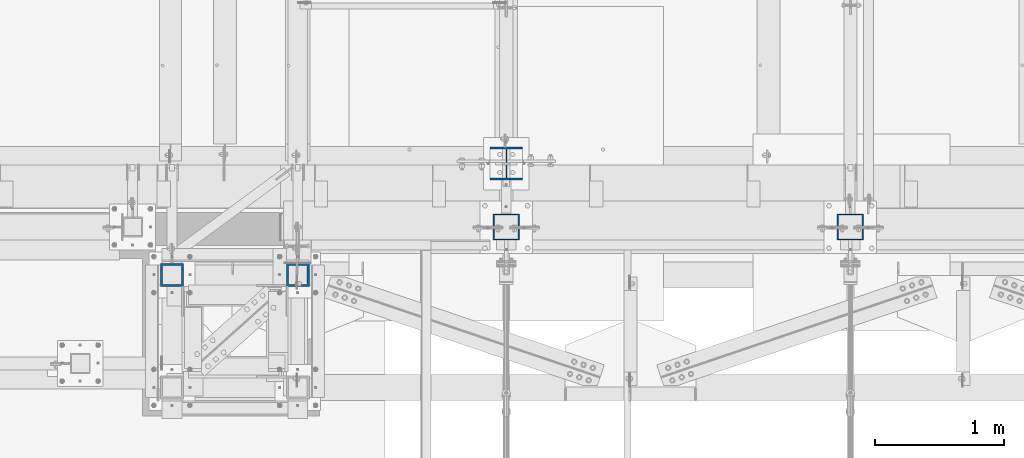
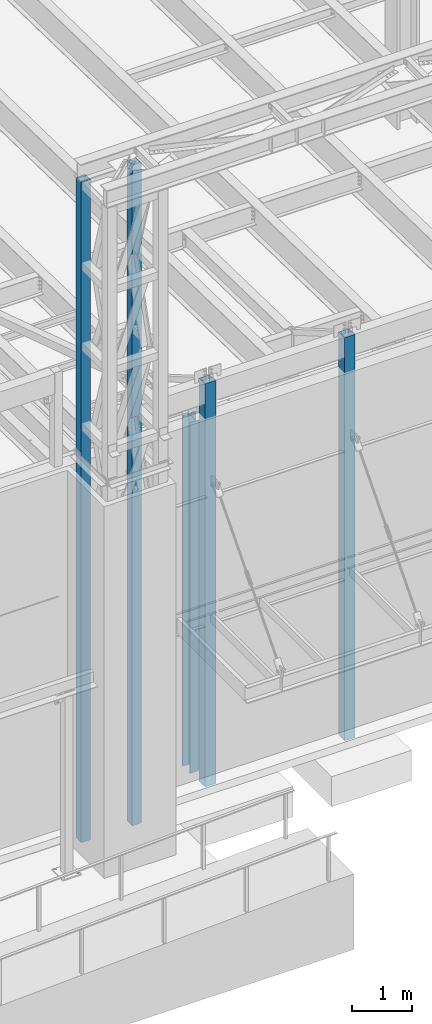
# One storey, part 891 of 1763: 5 columns, 4 elements without a shape of their own.
"""IFC2X3 building model written with IfcOpenShell, lengths in millimetres."""

from ifc_helpers import new_model, si_unit, frame, origin_with_axes, place, context, subcontext, project, spatial, faceted_brep, material, type_object, element, aggregate, save


model = new_model("IFC2X3")

# Units and contexts
model_context = context("Model", 3, precision=1e-05, world=origin_with_axes())
body_context = subcontext(model_context, "Body", "Model", "MODEL_VIEW")
ifc_project = project(units=[si_unit("LENGTHUNIT", "METRE", prefix="MILLI"), si_unit("AREAUNIT", "SQUARE_METRE"), si_unit("VOLUMEUNIT", "CUBIC_METRE"), si_unit("MASSUNIT", "GRAM", prefix="KILO"), si_unit("TIMEUNIT", "SECOND"), si_unit("PLANEANGLEUNIT", "RADIAN"), si_unit("SOLIDANGLEUNIT", "STERADIAN"), si_unit("THERMODYNAMICTEMPERATUREUNIT", "DEGREE_CELSIUS"), si_unit("LUMINOUSINTENSITYUNIT", "LUMEN")], contexts=[model_context])

# Site, building, storey
site_placement = place(None, origin_with_axes())
site = spatial("IfcSite", under=ifc_project, at=site_placement, CompositionType="ELEMENT")
building_placement = place(site_placement, origin_with_axes())
building = spatial("IfcBuilding", under=site, at=building_placement, Name="Undefined", CompositionType="ELEMENT")
storey_placement = place(building_placement, origin_with_axes())
storey = spatial("IfcBuildingStorey", under=building, at=storey_placement, Name="Undefined", CompositionType="ELEMENT", Elevation=0.0)

# Assembly, columns
assembly_1_placement = place(storey_placement, origin_with_axes())
assembly_1 = element("IfcElementAssembly", 1, at=assembly_1_placement, inside=storey, Name="FRAME", AssemblyPlace="NOTDEFINED", PredefinedType="RIGID_FRAME")
ifc_material_1 = material()
column_type_1 = type_object("IfcColumnType", Name="HSS7X7X5/8", PredefinedType="NOTDEFINED")
column_1_placement = place(assembly_1_placement, frame((-63210.5025957005, -14579.6023151462, 5029.2), z_axis=(0.0, 1.0, 0.0), x_axis=(0.0, 0.0, 1.0)))
column_1 = element("IfcColumn", 2, at=column_1_placement, type_object=column_type_1, material=ifc_material_1, Name="COLUMN", ObjectType="HSS7X7X5/8", context=body_context, shape_type="Brep", body=[
    faceted_brep([(63.5000000000009, 73.0250000000015, -73.0249999999996), (63.5000000000009, -73.0250000000015, -73.0249999999996), (13420.725, -73.0250000000015, -73.0249999999996), (13420.725, 73.0250000000015, -73.0249999999996), (63.5000000000009, -73.0250000000015, 73.0249999999996), (13420.725, -73.0250000000015, 73.0249999999996), (63.5000000000009, 73.0250000000015, 73.0249999999996), (13420.725, 73.0250000000015, 73.0249999999996), (63.5000000000009, 88.9000000000015, -88.8999999999996), (63.5000000000009, 88.9000000000015, 88.8999999999996), (13420.725, 88.9000000000015, 88.8999999999996), (13420.725, 88.9000000000015, -88.8999999999996), (63.5000000000009, -88.9000000000015, 88.8999999999996), (13420.725, -88.9000000000015, 88.8999999999996), (63.5000000000009, -88.9000000000015, -88.8999999999996), (13420.725, -88.9000000000015, -88.8999999999996)], [[[0, 1, 2, 3]], [[1, 4, 5, 2]], [[4, 6, 7, 5]], [[6, 0, 3, 7]], [[8, 9, 10, 11]], [[9, 12, 13, 10]], [[12, 14, 15, 13]], [[14, 8, 11, 15]], [[13, 15, 11, 10], [5, 7, 3, 2]], [[14, 12, 9, 8], [6, 4, 1, 0]]]),
])
column_2_placement = place(assembly_1_placement, frame((-64185.2277910131, -14579.6023151462, 5029.2), z_axis=(0.0, 1.0, 0.0), x_axis=(0.0, 0.0, 1.0)))
column_2 = element("IfcColumn", 3, at=column_2_placement, type_object=column_type_1, material=ifc_material_1, Name="COLUMN", ObjectType="HSS7X7X5/8", context=body_context, shape_type="Brep", body=[
    faceted_brep([(63.5000000000009, 73.0250000000015, -73.0249999999996), (63.5000000000009, -73.0250000000015, -73.0249999999996), (13420.725, -73.0250000000015, -73.0249999999996), (13420.725, 73.0250000000015, -73.0249999999996), (63.5000000000009, -73.0250000000015, 73.0249999999996), (13420.725, -73.0250000000015, 73.0249999999996), (63.5000000000009, 73.0250000000015, 73.0249999999996), (13420.725, 73.0250000000015, 73.0249999999996), (63.5000000000009, 88.9000000000015, -88.8999999999996), (63.5000000000009, 88.9000000000015, 88.8999999999996), (13420.725, 88.9000000000015, 88.8999999999996), (13420.725, 88.9000000000015, -88.8999999999996), (63.5000000000009, -88.9000000000015, 88.8999999999996), (13420.725, -88.9000000000015, 88.8999999999996), (63.5000000000009, -88.9000000000015, -88.8999999999996), (13420.725, -88.9000000000015, -88.8999999999996)], [[[0, 1, 2, 3]], [[1, 4, 5, 2]], [[4, 6, 7, 5]], [[6, 0, 3, 7]], [[8, 9, 10, 11]], [[9, 12, 13, 10]], [[12, 14, 15, 13]], [[14, 8, 11, 15]], [[13, 15, 11, 10], [5, 7, 3, 2]], [[14, 12, 9, 8], [6, 4, 1, 0]]]),
])
aggregate(assembly_1, [column_1, column_2])

# Assembly, column
assembly_2_placement = place(storey_placement, origin_with_axes())
assembly_2 = element("IfcElementAssembly", 4, at=assembly_2_placement, inside=storey, Name="COLUMN", AssemblyPlace="NOTDEFINED", PredefinedType="RIGID_FRAME")
ifc_material_2 = material(Name="STEEL/A992")
column_type_2 = type_object("IfcColumnType", Name="W10X49", PredefinedType="NOTDEFINED")
column_3_placement = place(assembly_2_placement, frame((-61594.4372736983, -13716.0, 5029.2), z_axis=(0.0, 1.0, 0.0), x_axis=(0.0, 0.0, 1.0)))
column_3 = element("IfcColumn", 5, at=column_3_placement, type_object=column_type_2, material=ifc_material_2, Name="COLUMN", ObjectType="W10X49", context=body_context, shape_type="Brep", body=[
    faceted_brep([(69.8500000000085, 127.0, -127.0), (69.8500000000085, 127.0, -112.712500000001), (7156.45000000001, 127.0, -112.7125), (7156.45000000001, 127.0, -127.0), (69.8500000000085, 3.96875, -112.712500000001), (7156.45000000001, 3.96875, -112.7125), (69.8500000000085, 3.96875, 112.712500000001), (7156.45000000001, 3.96875, 112.7125), (69.8500000000085, 127.0, 112.712500000001), (7156.45000000001, 127.0, 112.7125), (69.8500000000085, 127.0, 127.0), (7156.45000000001, 127.0, 127.0), (69.8500000000085, -127.0, 127.0), (7156.45000000001, -127.0, 127.0), (69.8500000000085, -127.0, 112.712500000001), (7156.45000000001, -127.0, 112.7125), (69.8500000000085, -3.96875, 112.712500000001), (7156.45000000001, -3.96875, 112.7125), (69.8500000000085, -3.96875, -112.712500000001), (7156.45000000001, -3.96875, -112.7125), (69.8500000000085, -127.0, -112.712500000001), (7156.45000000001, -127.0, -112.7125), (69.8500000000085, -127.0, -127.0), (7156.45000000001, -127.0, -127.0)], [[[0, 1, 2, 3]], [[1, 4, 5, 2]], [[4, 6, 7, 5]], [[6, 8, 9, 7]], [[8, 10, 11, 9]], [[10, 12, 13, 11]], [[12, 14, 15, 13]], [[14, 16, 17, 15]], [[16, 18, 19, 17]], [[18, 20, 21, 19]], [[20, 22, 23, 21]], [[22, 0, 3, 23]], [[5, 7, 9, 11, 13, 15, 17, 19, 21, 23, 3, 2]], [[22, 20, 18, 16, 14, 12, 10, 8, 6, 4, 1, 0]]]),
])
aggregate(assembly_2, [column_3])

assembly_3_placement = place(storey_placement, origin_with_axes())
assembly_3 = element("IfcElementAssembly", 6, at=assembly_3_placement, inside=storey, Name="COLUMN", AssemblyPlace="NOTDEFINED", PredefinedType="RIGID_FRAME")
column_type_3 = type_object("IfcColumnType", Name="HSS8X8X3/8", PredefinedType="NOTDEFINED")
column_4_placement = place(assembly_3_placement, frame((-58927.4270098567, -14208.1276214906, 5029.2), z_axis=(0.0, 1.0, 0.0), x_axis=(0.0, 0.0, 1.0)))
column_4 = element("IfcColumn", 7, at=column_4_placement, type_object=column_type_3, material=ifc_material_1, Name="COLUMN", ObjectType="HSS8X8X3/8", context=body_context, shape_type="Brep", body=[
    faceted_brep([(69.8499999999976, 92.0749999999971, -92.0750000000007), (69.8499999999976, -92.0749999999971, -92.0750000000007), (8223.27212579575, -92.0749999999971, -92.0750000000007), (8223.27212579575, 92.0749999999971, -92.0750000000007), (69.8499999999976, -92.0749999999971, 92.0750000000007), (8223.27212579575, -92.0749999999971, 92.0750000000007), (69.8499999999976, 92.0749999999971, 92.0750000000007), (8223.27212579575, 92.0749999999971, 92.0750000000007), (69.8499999999976, 101.599999999999, -101.6), (69.8499999999976, 101.599999999999, 101.6), (8223.27212579575, 101.599999999999, 101.6), (8223.27212579575, 101.599999999999, -101.6), (69.8499999999976, -101.599999999999, 101.6), (8223.27212579575, -101.599999999999, 101.6), (69.8499999999976, -101.599999999999, -101.6), (8223.27212579575, -101.599999999999, -101.6)], [[[0, 1, 2, 3]], [[1, 4, 5, 2]], [[4, 6, 7, 5]], [[6, 0, 3, 7]], [[8, 9, 10, 11]], [[9, 12, 13, 10]], [[12, 14, 15, 13]], [[14, 8, 11, 15]], [[13, 15, 11, 10], [5, 7, 3, 2]], [[14, 12, 9, 8], [6, 4, 1, 0]]]),
])
aggregate(assembly_3, [column_4])

assembly_4_placement = place(storey_placement, origin_with_axes())
assembly_4 = element("IfcElementAssembly", 8, at=assembly_4_placement, inside=storey, Name="COLUMN", AssemblyPlace="NOTDEFINED", PredefinedType="RIGID_FRAME")
column_5_placement = place(assembly_4_placement, frame((-61594.4270098568, -14208.1276214906, 5029.2), z_axis=(0.0, 1.0, 0.0), x_axis=(0.0, 0.0, 1.0)))
column_5 = element("IfcColumn", 9, at=column_5_placement, type_object=column_type_3, material=ifc_material_1, Name="COLUMN", ObjectType="HSS8X8X3/8", context=body_context, shape_type="Brep", body=[
    faceted_brep([(69.8499999999976, 92.0749999999971, -92.0750000000007), (69.8499999999976, -92.0749999999971, -92.0750000000007), (8223.27212579575, -92.0749999999971, -92.0750000000007), (8223.27212579575, 92.0749999999971, -92.0750000000007), (69.8499999999976, -92.0749999999971, 92.0750000000007), (8223.27212579575, -92.0749999999971, 92.0750000000007), (69.8499999999976, 92.0749999999971, 92.0750000000007), (8223.27212579575, 92.0749999999971, 92.0750000000007), (69.8499999999976, 101.599999999999, -101.6), (69.8499999999976, 101.599999999999, 101.6), (8223.27212579575, 101.599999999999, 101.6), (8223.27212579575, 101.599999999999, -101.6), (69.8499999999976, -101.599999999999, 101.6), (8223.27212579575, -101.599999999999, 101.6), (69.8499999999976, -101.599999999999, -101.6), (8223.27212579575, -101.599999999999, -101.6)], [[[0, 1, 2, 3]], [[1, 4, 5, 2]], [[4, 6, 7, 5]], [[6, 0, 3, 7]], [[8, 9, 10, 11]], [[9, 12, 13, 10]], [[12, 14, 15, 13]], [[14, 8, 11, 15]], [[13, 15, 11, 10], [5, 7, 3, 2]], [[14, 12, 9, 8], [6, 4, 1, 0]]]),
])
aggregate(assembly_4, [column_5])

save(model, "model.ifc")
